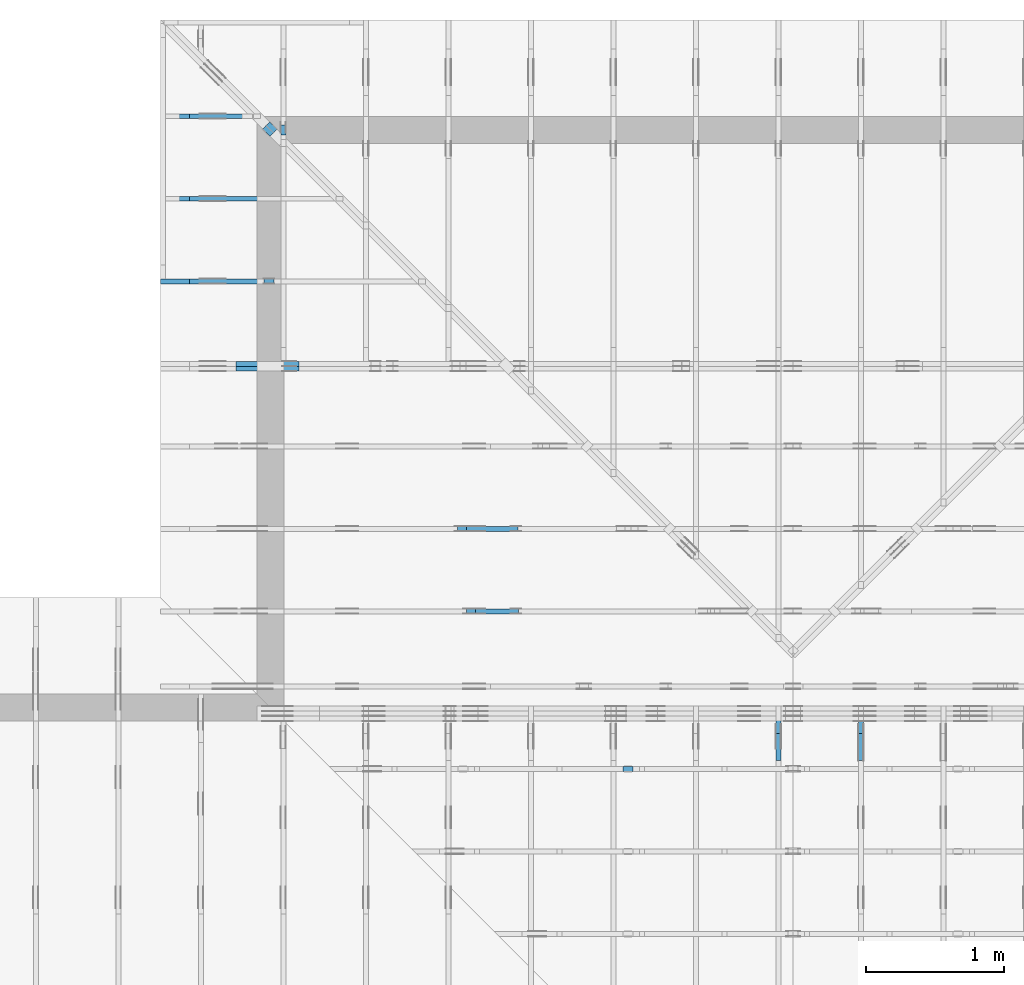
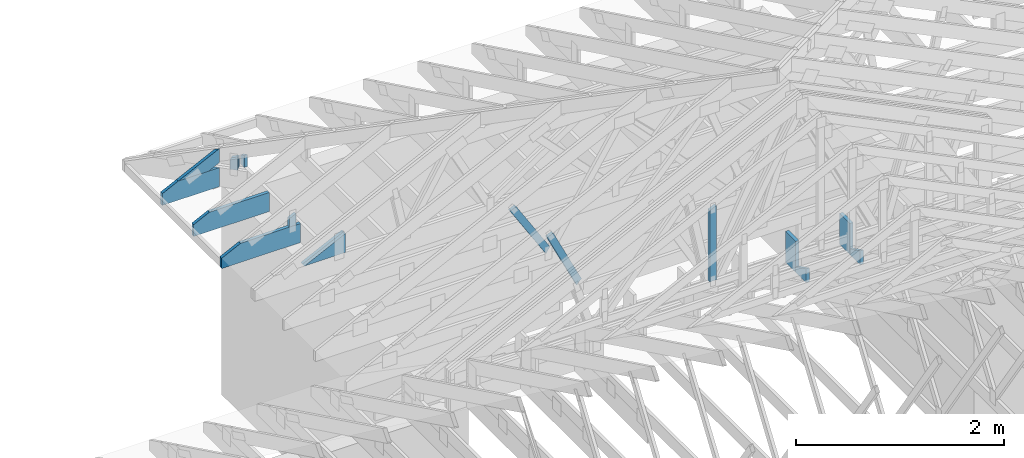
# One storey, part 46 of 159: 17 members, 11 elements without a shape of their own.
"""IFC2X3 building model written with IfcOpenShell, lengths in millimetres."""

import ifcopenshell
import ifcopenshell.guid

model = None  # the IFC model being written
_history = None  # IfcOwnerHistory: only IFC2X3 demands one
_inside = {}  # id of a spatial element -> (the spatial element, [elements in it])
_under = {}  # id of a project, library or spatial element -> (it, [spatial elements below it])
_declared = {}  # id of a project -> (the project, [libraries it declares])
_typed = {}  # id of a type object -> (the type object, [elements of that type])
_made_of = {}  # id of a material, layer set ... -> (it, [elements and type objects made of it])


def new_model(schema):
    """Start an empty IFC model of exactly this schema.

    Asked for "IFC4X3", IfcOpenShell would pick the latest addendum, in which some entities
    have other attributes; the version numbers below select the first issue.
    IFC2X3 requires an IfcOwnerHistory on every rooted entity: one is made here for all.
    """
    global model, _history
    if schema == "IFC4X3":
        model = ifcopenshell.file(schema_version=(4, 3, 0, 0))
    else:
        model = ifcopenshell.file(schema=schema)
    _inside.clear()
    _under.clear()
    _declared.clear()
    _typed.clear()
    _made_of.clear()
    _history = None
    if model.schema == "IFC2X3":
        org = make("IfcOrganization", Name="unknown")
        user = make(
            "IfcPersonAndOrganization",
            ThePerson=make("IfcPerson", FamilyName="unknown"),
            TheOrganization=org,
        )
        app = make(
            "IfcApplication",
            ApplicationDeveloper=org,
            Version="unknown",
            ApplicationFullName="unknown",
            ApplicationIdentifier="unknown",
        )
        _history = make(
            "IfcOwnerHistory",
            OwningUser=user,
            OwningApplication=app,
            ChangeAction="ADDED",
            CreationDate=0,
        )
    return model


def make(cls, **values):
    """One entity of the class cls with the attributes given. An attribute that is None is left unset."""
    return model.create_entity(
        cls, **{name: value for name, value in values.items() if value is not None}
    )


def rooted(cls, **values):
    """An entity with a GlobalId (a new one), such as an element, a storey or a relation."""
    return make(cls, GlobalId=ifcopenshell.guid.new(), OwnerHistory=_history, **values)


def si_unit(unit_type, name, prefix=None):
    """IfcSIUnit, for example si_unit("LENGTHUNIT", "METRE", prefix="MILLI")."""
    return make("IfcSIUnit", UnitType=unit_type, Prefix=prefix, Name=name)


def assignment(units):
    """IfcUnitAssignment: the units of a project."""
    return None if units is None else make("IfcUnitAssignment", Units=units)


def point(xyz):
    """IfcCartesianPoint."""
    return None if xyz is None else make("IfcCartesianPoint", Coordinates=xyz)


def direction(xyz):
    """IfcDirection."""
    return None if xyz is None else make("IfcDirection", DirectionRatios=xyz)


def frame(location, z_axis=None, x_axis=None):
    """IfcAxis2Placement3D, a coordinate frame: its origin and axes. An axis left out is left unset."""
    return make(
        "IfcAxis2Placement3D",
        Location=point(location),
        Axis=direction(z_axis),
        RefDirection=direction(x_axis),
    )


def frame_2d(location, x_axis=None):
    """IfcAxis2Placement2D, a coordinate frame in the plane: its origin and x axis."""
    return make(
        "IfcAxis2Placement2D", Location=point(location), RefDirection=direction(x_axis)
    )


def origin():
    """The frame at (0, 0, 0) with its axes left unset."""
    return frame((0.0, 0.0, 0.0))


def origin_with_axes():
    """The frame at (0, 0, 0) with the z axis (0, 0, 1) and the x axis (1, 0, 0) written out."""
    return frame((0.0, 0.0, 0.0), z_axis=(0.0, 0.0, 1.0), x_axis=(1.0, 0.0, 0.0))


def origin_2d():
    """The frame at (0, 0) in the plane with its x axis left unset."""
    return frame_2d((0.0, 0.0))


def place(relative_to, where):
    """IfcLocalPlacement: puts the frame where relative to a parent placement (None: the world)."""
    return make(
        "IfcLocalPlacement", PlacementRelTo=relative_to, RelativePlacement=where
    )


def context(
    kind, dimensions, precision=None, world=None, true_north=None, identifier=None
):
    """IfcGeometricRepresentationContext, for example the 3D "Model" context."""
    return make(
        "IfcGeometricRepresentationContext",
        ContextIdentifier=identifier,
        ContextType=kind,
        CoordinateSpaceDimension=dimensions,
        Precision=precision,
        WorldCoordinateSystem=world,
        TrueNorth=true_north,
    )


def project(units=None, contexts=None):
    """IfcProject with its units and contexts."""
    return rooted(
        "IfcProject",
        Name="project",
        RepresentationContexts=contexts,
        UnitsInContext=assignment(units),
    )


def spatial(cls, under=None, at=None, **own):
    """A site, building, storey or space (cls), placed at a placement, below another one or the project."""
    s = rooted(cls, ObjectPlacement=at, **own)
    if under is not None:
        _under.setdefault(under.id(), (under, []))[1].append(s)
    return s


def faces_of(points, faces, orient=None, outer=None):
    """IfcFace entities. A face is a list of loops; a loop is a list of indices into points, from 0.

    orient and outer hold one flag for each loop. By default every Orientation is true, the
    first loop of a face is its IfcFaceOuterBound and the others are IfcFaceBound.
    """
    made = []
    for i, loops in enumerate(faces):
        bounds = []
        for j, loop in enumerate(loops):
            is_outer = j == 0 if outer is None else outer[i][j]
            bounds.append(
                make(
                    "IfcFaceOuterBound" if is_outer else "IfcFaceBound",
                    Bound=make("IfcPolyLoop", Polygon=[points[k] for k in loop]),
                    Orientation=True if orient is None else orient[i][j],
                )
            )
        made.append(make("IfcFace", Bounds=bounds))
    return made


def faceted_brep(points, faces, orient=None, outer=None, voids=None):
    """IfcFacetedBrep: a solid bounded by flat faces; with voids (closed shells), ...WithVoids."""
    shared = [point(p) for p in points]
    hull = make("IfcClosedShell", CfsFaces=faces_of(shared, faces, orient, outer))
    if voids is None:
        return make("IfcFacetedBrep", Outer=hull)
    return make(
        "IfcFacetedBrepWithVoids",
        Outer=hull,
        Voids=[
            make(cls, CfsFaces=faces_of(shared, fs, o, b)) for cls, fs, o, b in voids
        ],
    )


def shape(context_of_items, identifier, shape_type, items):
    """IfcShapeRepresentation: the items that make up one representation, for example the "Body"."""
    return make(
        "IfcShapeRepresentation",
        ContextOfItems=context_of_items,
        RepresentationIdentifier=identifier,
        RepresentationType=shape_type,
        Items=items,
    )


def made_of(thing, what):
    """Note that an element or type object is made of a material, layer set ...; save() writes the relation."""
    if what is not None:
        _made_of.setdefault(what.id(), (what, []))[1].append(thing)
    return thing


def element(
    cls,
    number,
    at=None,
    inside=None,
    cuts=None,
    type_object=None,
    material=None,
    context=None,
    identifier="Body",
    shape_type=None,
    held_by="IfcProductDefinitionShape",
    body=None,
    shapes=None,
    **own,
):
    """One element of the class cls, such as IfcWall. Its Tag is "e" and its number.

    at: its placement. inside: the storey or other place that contains it. cuts: it is an
    opening in that element (IfcRelVoidsElement). A single representation is given by context,
    identifier, shape_type and body (its items); several are given by shapes. held_by: the class
    of the entity that holds the representations. save() writes the other relations.
    """
    e = rooted(cls, Tag="e%d" % number, ObjectPlacement=at, **own)
    if body is not None:
        shapes = [shape(context, identifier, shape_type, body)]
    if shapes is not None:
        e.Representation = make(held_by, Representations=shapes)
    if inside is not None:
        _inside.setdefault(inside.id(), (inside, []))[1].append(e)
    if cuts is not None:
        rooted(
            "IfcRelVoidsElement", RelatingBuildingElement=cuts, RelatedOpeningElement=e
        )
    if type_object is not None:
        _typed.setdefault(type_object.id(), (type_object, []))[1].append(e)
    return made_of(e, material)


def aggregate(whole, parts):
    """IfcRelAggregates: a whole, such as a stair, and the parts it consists of."""
    return rooted("IfcRelAggregates", RelatingObject=whole, RelatedObjects=parts)


def save(model, path):
    """Write the relations noted so far, then the file.

    IfcRelAggregates (storeys below a building ...), IfcRelContainedInSpatialStructure (elements
    in a storey), IfcRelDefinesByType, IfcRelAssociatesMaterial and IfcRelDeclares: one each for
    every whole, place, type object, material and project.
    """
    for whole, parts in _under.values():
        aggregate(whole, parts)
    for where, things in _inside.values():
        rooted(
            "IfcRelContainedInSpatialStructure",
            RelatedElements=things,
            RelatingStructure=where,
        )
    for kind, things in _typed.values():
        rooted("IfcRelDefinesByType", RelatedObjects=things, RelatingType=kind)
    for what, things in _made_of.values():
        rooted("IfcRelAssociatesMaterial", RelatedObjects=things, RelatingMaterial=what)
    for by, libraries in _declared.values():
        rooted("IfcRelDeclares", RelatingContext=by, RelatedDefinitions=libraries)
    model.write(path)


model = new_model("IFC2X3")

# Units and contexts
model_context = context("Model", 3, precision=1e-05, world=origin())
plan_context = context("Plan", 2, precision=1e-05, world=origin_2d())
ifc_project = project(units=[si_unit("LENGTHUNIT", "METRE", prefix="MILLI"), si_unit("AREAUNIT", "SQUARE_METRE"), si_unit("VOLUMEUNIT", "CUBIC_METRE"), si_unit("SOLIDANGLEUNIT", "STERADIAN"), si_unit("PLANEANGLEUNIT", "RADIAN"), si_unit("MASSUNIT", "GRAM"), si_unit("TIMEUNIT", "SECOND"), si_unit("THERMODYNAMICTEMPERATUREUNIT", "DEGREE_CELSIUS"), si_unit("LUMINOUSINTENSITYUNIT", "LUMEN")], contexts=[model_context, plan_context])

# Site, building, storey
site_placement = place(None, origin_with_axes())
site = spatial("IfcSite", under=ifc_project, at=site_placement, CompositionType="ELEMENT")
building_placement = place(site_placement, origin_with_axes())
building = spatial("IfcBuilding", under=site, at=building_placement, Name="Plan 1", CompositionType="ELEMENT")
storey_placement = place(building_placement, origin_with_axes())
storey = spatial("IfcBuildingStorey", under=building, at=storey_placement, Name="Etasje 1", CompositionType="ELEMENT", Elevation=0.0)

# Assembly, member
assembly_1_placement = place(storey_placement, frame((19200.01266310149, 9617.999978540158, 1.1021457184401395e-15), z_axis=(1.2246063538223773e-16, 1.0, 6.123031769111886e-17), x_axis=(-1.0, 1.2246063538223773e-16, 0.0)))
assembly_1 = element("IfcElementAssembly", 1, at=assembly_1_placement, inside=storey, Name="V12 (104)", AssemblyPlace="FACTORY", PredefinedType="TRUSS")
member_1_placement = place(assembly_1_placement, frame((6910.824282017095, 1071.8405838183317, -36.0), z_axis=(0.0, 0.0, 1.0), x_axis=(-0.43837114678907774, -0.8987940462991668, 0.0)))
member_1 = element("IfcMember", 2, at=member_1_placement, Name="V12-D64", context=model_context, shape_type="Brep", body=[
    faceted_brep([(744.1520057801918, 73.00022302085836, 36.0), (0.0, 73.00022302085836, 36.0), (0.00014432312946155434, 0.0, 36.0), (714.8608321408219, 0.0, 36.0), (0.0, 73.00022302085836, 0.0), (744.1520057801918, 73.00022302085836, 9.112932744880892e-14), (714.8608321408219, 0.0, 8.754231171384024e-14), (0.00014432312946155434, 0.0, 1.7673902134214898e-20), (6.50678757665446e-05, 0.0002128465330315521, 7.52316384526264e-37), (6.50678757687489e-05, 0.0002128465330315521, 36.0), (6.50678962337698e-05, 73.00021284653394, 36.0), (6.50678962315655e-05, 73.00021284653394, -8.511632342891698e-32), (714.8608697602031, 0.00021284653417008646, 4.1664479062748666e-29), (714.8608697602031, 0.00021284653417229075, 36.0), (6.50678757665446e-05, 0.00021284653303375634, 36.0), (6.50678757665446e-05, 0.00021284653303155204, 4.513898307157584e-36), (744.1520107425414, 73.00021284653388, 6.310887241768095e-30), (744.1520107425414, 73.00021284653388, 36.0), (714.8608697602032, 0.0002128465348789632, 36.0), (714.8608697602032, 0.0002128465348789632, 0.0), (6.506789623017539e-05, 73.00021284653394, 0.0), (6.506789623017539e-05, 73.00021284653394, 36.0), (744.1520107425413, 73.0002128465339, 36.0), (744.1520107425413, 73.0002128465339, -3.1554436208840472e-30)], [[[0, 1, 2, 3]], [[4, 5, 6, 7]], [[8, 9, 10, 11]], [[12, 13, 14, 15]], [[16, 17, 18, 19]], [[20, 21, 22, 23]]]),
])
aggregate(assembly_1, [member_1])

# Assembly, members
assembly_2_placement = place(storey_placement, frame((15075.02226140475, -699.9989301294845, 1.1021457184401395e-15), z_axis=(-1.0, 1.836909530733566e-16, 6.123031769111886e-17), x_axis=(-1.836909530733566e-16, -1.0, 0.0)))
assembly_2 = element("IfcElementAssembly", 3, at=assembly_2_placement, inside=storey, Name="T7 (103)", AssemblyPlace="FACTORY", PredefinedType="TRUSS")
member_2_placement = place(assembly_2_placement, frame((-9411.99893013318, 371.0, -36.0), z_axis=(0.0, 0.0, 1.0), x_axis=(-2.6074085653169515e-12, 1.0, 0.0)))
member_2 = element("IfcMember", 4, at=member_2_placement, Name="T7-S1", context=model_context, shape_type="Brep", body=[
    faceted_brep([(363.47723388723495, 198.0000933033716, 36.0), (5.162519300938584e-10, 198.0000933033716, 36.0), (0.0, 9.330431930720806e-05, 36.0), (363.4772338867187, 9.330431930720806e-05, 36.0), (5.162519300938584e-10, 198.0000933033716, 6.322053937660047e-26), (363.47723388723495, 198.0000933033716, 4.4511653008809024e-14), (363.4772338867187, 9.330431930720806e-05, 4.45116530087458e-14), (0.0, 9.330431930720806e-05, 0.0), (0.0, 0.0, 0.0), (2.204291436880279e-15, -5.7474038303501e-27, 36.0), (5.162615062011267e-10, 198.0, 36.0), (5.162593019096898e-10, 198.0, -4.513786253158592e-31), (363.47721516495375, 6.308078123434283e-08, -2.921223515766118e-30), (363.47721516495375, 6.308078343863427e-08, 36.0), (-3.825505976859566e-25, 2.204291436880279e-15, 36.0), (0.0, 0.0, 0.0), (363.47721516495375, 198.0000000612181, -3.16080787503955e-26), (363.47721516495375, 198.0000000612181, 36.0), (363.47721516495375, 6.308073352556676e-08, 36.0), (363.47721516495375, 6.308073352556676e-08, 0.0), (5.162519300938584e-10, 198.0, 0.0), (5.162519300938584e-10, 198.0, 36.0), (363.47721516547, 198.0000000612181, 36.0), (363.47721516547, 198.0000000612181, -1.5777218104420236e-30)], [[[0, 1, 2, 3]], [[4, 5, 6, 7]], [[8, 9, 10, 11]], [[12, 13, 14, 15]], [[16, 17, 18, 19]], [[20, 21, 22, 23]]]),
])
member_3_placement = place(assembly_2_placement, frame((-9213.998930133188, 371.0, -36.0), z_axis=(0.0, 0.0, 1.0), x_axis=(-1.7615569541788202e-10, 1.0, 0.0)))
member_3 = element("IfcMember", 5, at=member_3_placement, Name="T7-S5", context=model_context, shape_type="Brep", body=[
    faceted_brep([(66.21466067941009, 198.00009329264867, 36.0), (3.4878837595897494e-08, 198.00009329264867, 36.0), (0.0, 9.330431203125045e-05, 36.0), (162.7857055664063, 9.330431203125045e-05, 36.0), (3.4878837595897494e-08, 198.00009329264867, 4.271284613387488e-24), (66.21466067941009, 198.00009329264867, 8.108689418419832e-15), (162.7857055664063, 9.330431203125045e-05, 1.9934840934807988e-14), (0.0, 9.330431203125045e-05, 0.0), (-2.605355528885784e-24, 6.255140760913491e-08, 1.5952674669991638e-40), (2.2042914342749235e-15, 6.255140760913491e-08, 36.0), (3.487882230300644e-08, 198.00000006253686, 36.0), (3.4878820098715006e-08, 198.00000006253686, 1.071358042460672e-30), (162.78571493316844, -3.9667248731015275e-14, 2.4288382424236155e-30), (162.78571493316844, -3.7462957294134996e-14, 36.0), (8.470130163630552e-25, 6.255140981342635e-08, 36.0), (0.0, 6.255140760913491e-08, 0.0), (66.21466011511593, 198.0, 0.0), (66.21466011511593, 198.0, 36.0), (162.78571493316844, 1.4210854715202004e-14, 36.0), (162.78571493316846, 1.4210854715202004e-14, 1.5777218104420236e-30), (3.4878837595897494e-08, 198.00000006253686, 0.0), (3.4878837595897494e-08, 198.00000006253686, 36.0), (66.21466011511592, 198.0, 36.0), (66.21466011511592, 198.0, 0.0)], [[[0, 1, 2, 3]], [[4, 5, 6, 7]], [[8, 9, 10, 11]], [[12, 13, 14, 15]], [[16, 17, 18, 19]], [[20, 21, 22, 23]]]),
])
aggregate(assembly_2, [member_2, member_3])

assembly_3_placement = place(storey_placement, frame((14475.022261404752, -699.9989301294836, 1.1021457184401395e-15), z_axis=(-1.0, 1.836909530733566e-16, 6.123031769111886e-17), x_axis=(-1.836909530733566e-16, -1.0, 0.0)))
assembly_3 = element("IfcElementAssembly", 6, at=assembly_3_placement, inside=storey, Name="T10 (102)", AssemblyPlace="FACTORY", PredefinedType="TRUSS")
member_4_placement = place(assembly_3_placement, frame((-9411.99893013318, 371.0, -36.0), z_axis=(0.0, 0.0, 1.0), x_axis=(-2.6074085653169515e-12, 1.0, 0.0)))
member_4 = element("IfcMember", 7, at=member_4_placement, Name="T10-S1", context=model_context, shape_type="Brep", body=[
    faceted_brep([(363.47723388723495, 198.0000933033716, 36.0), (5.162519300938584e-10, 198.0000933033716, 36.0), (0.0, 9.330431930720806e-05, 36.0), (363.4772338867187, 9.330431930720806e-05, 36.0), (5.162519300938584e-10, 198.0000933033716, 6.322053937660047e-26), (363.47723388723495, 198.0000933033716, 4.4511653008809024e-14), (363.4772338867187, 9.330431930720806e-05, 4.45116530087458e-14), (0.0, 9.330431930720806e-05, 0.0), (0.0, 0.0, 0.0), (2.204291436880279e-15, -5.7474038303501e-27, 36.0), (5.162615062011267e-10, 198.0, 36.0), (5.162593019096898e-10, 198.0, -4.513786253158592e-31), (363.47721516495375, 6.308078123434283e-08, -2.921223515766118e-30), (363.47721516495375, 6.308078343863427e-08, 36.0), (-3.825505976859566e-25, 2.204291436880279e-15, 36.0), (0.0, 0.0, 0.0), (363.47721516495375, 198.0000000612181, -3.16080787503955e-26), (363.47721516495375, 198.0000000612181, 36.0), (363.47721516495375, 6.308073352556676e-08, 36.0), (363.47721516495375, 6.308073352556676e-08, 0.0), (5.162519300938584e-10, 198.0, 0.0), (5.162519300938584e-10, 198.0, 36.0), (363.47721516547, 198.0000000612181, 36.0), (363.47721516547, 198.0000000612181, -1.5777218104420236e-30)], [[[0, 1, 2, 3]], [[4, 5, 6, 7]], [[8, 9, 10, 11]], [[12, 13, 14, 15]], [[16, 17, 18, 19]], [[20, 21, 22, 23]]]),
])
member_5_placement = place(assembly_3_placement, frame((-9213.998930133188, 371.0, -36.0), z_axis=(0.0, 0.0, 1.0), x_axis=(-1.7615569541788202e-10, 1.0, 0.0)))
member_5 = element("IfcMember", 8, at=member_5_placement, Name="T10-S5", context=model_context, shape_type="Brep", body=[
    faceted_brep([(66.21466067941009, 198.00009329264867, 36.0), (3.4878837595897494e-08, 198.00009329264867, 36.0), (0.0, 9.330431203125045e-05, 36.0), (162.7857055664063, 9.330431203125045e-05, 36.0), (3.4878837595897494e-08, 198.00009329264867, 4.271284613387488e-24), (66.21466067941009, 198.00009329264867, 8.108689418419832e-15), (162.7857055664063, 9.330431203125045e-05, 1.9934840934807988e-14), (0.0, 9.330431203125045e-05, 0.0), (-2.605355528885784e-24, 6.255140760913491e-08, 1.5952674669991638e-40), (2.2042914342749235e-15, 6.255140760913491e-08, 36.0), (3.487882230300644e-08, 198.00000006253686, 36.0), (3.4878820098715006e-08, 198.00000006253686, 1.071358042460672e-30), (162.78571493316844, -3.9667248731015275e-14, 2.4288382424236155e-30), (162.78571493316844, -3.7462957294134996e-14, 36.0), (8.470130163630552e-25, 6.255140981342635e-08, 36.0), (0.0, 6.255140760913491e-08, 0.0), (66.21466011511593, 198.0, 0.0), (66.21466011511593, 198.0, 36.0), (162.78571493316844, 1.4210854715202004e-14, 36.0), (162.78571493316846, 1.4210854715202004e-14, 1.5777218104420236e-30), (3.4878837595897494e-08, 198.00000006253686, 0.0), (3.4878837595897494e-08, 198.00000006253686, 36.0), (66.21466011511592, 198.0, 36.0), (66.21466011511592, 198.0, 0.0)], [[[0, 1, 2, 3]], [[4, 5, 6, 7]], [[8, 9, 10, 11]], [[12, 13, 14, 15]], [[16, 17, 18, 19]], [[20, 21, 22, 23]]]),
])
aggregate(assembly_3, [member_4, member_5])

assembly_4_placement = place(storey_placement, frame((19200.01266310149, 11417.999978540158, 0.0), z_axis=(1.2246063538223773e-16, 1.0, 6.123031769111886e-17), x_axis=(-1.0, 1.2246063538223773e-16, 0.0)))
assembly_4 = element("IfcElementAssembly", 9, at=assembly_4_placement, inside=storey, Name="V9 (1)", AssemblyPlace="FACTORY", PredefinedType="TRUSS")
member_6_placement = place(assembly_4_placement, frame((8193.9873046875, 223.0, -36.0), z_axis=(0.0, 0.0, 1.0), x_axis=(1.0, 0.0, 0.0)))
member_6 = element("IfcMember", 10, at=member_6_placement, Name="V9-KI3", context=model_context, shape_type="Brep", body=[
    faceted_brep([(0.0, 223.0, 36.0), (0.0, 0.0, 36.0), (457.2177734375, 0.0, 36.0), (0.0, 223.0, 0.0), (457.2177734375, 0.0, 0.0), (0.0, 0.0, 0.0), (0.00018211813039670233, 0.0, 0.0), (0.00018211813039890662, -2.6993892992798474e-31, 36.0), (0.00018211813042621534, 223.0, 36.0), (0.00018211813042401105, 223.0, -1.67212096573961e-30), (457.21793879009783, -8.398679893858869e-14, 5.1425383808699095e-30), (457.21793879009783, -8.178250750170841e-14, 36.0), (0.00018211813039670233, 2.2042579834273344e-15, 36.0), (0.00018211813039670233, -3.3453452944508083e-20, 2.0483655516571257e-36), (0.00018211813039670233, 223.00000000000003, 1.2764860230108856e-30), (0.00018211813039670233, 223.00000000000003, 36.0), (457.21793879009783, -2.842170943040401e-14, 36.0), (457.21793879009783, -2.842170943040401e-14, -3.114004965666352e-31)], [[[0, 1, 2]], [[3, 4, 5]], [[6, 7, 8, 9]], [[10, 11, 12, 13]], [[14, 15, 16, 17]]]),
])
member_7_placement = place(assembly_4_placement, frame((8193.9873046875, 223.0, -72.0), z_axis=(0.0, 0.0, 1.0), x_axis=(1.0, 0.0, 0.0)))
member_7 = element("IfcMember", 11, at=member_7_placement, Name="V9-KI3", context=model_context, shape_type="Brep", body=[
    faceted_brep([(0.0, 223.0, 36.0), (0.0, 0.0, 36.0), (457.2177734375, 0.0, 36.0), (0.0, 223.0, 0.0), (457.2177734375, 0.0, 0.0), (0.0, 0.0, 0.0), (0.00018211813039670233, 0.0, 0.0), (0.00018211813039890662, -2.6993892992798474e-31, 36.0), (0.00018211813042621534, 223.0, 36.0), (0.00018211813042401105, 223.0, -1.67212096573961e-30), (457.21793879009783, -8.398679893858869e-14, 5.1425383808699095e-30), (457.21793879009783, -8.178250750170841e-14, 36.0), (0.00018211813039670233, 2.2042579834273344e-15, 36.0), (0.00018211813039670233, -3.3453452944508083e-20, 2.0483655516571257e-36), (0.00018211813039670233, 223.00000000000003, 1.2764860230108856e-30), (0.00018211813039670233, 223.00000000000003, 36.0), (457.21793879009783, -2.842170943040401e-14, 36.0), (457.21793879009783, -2.842170943040401e-14, -3.114004965666352e-31)], [[[0, 1, 2]], [[3, 4, 5]], [[6, 7, 8, 9]], [[10, 11, 12, 13]], [[14, 15, 16, 17]]]),
])
aggregate(assembly_4, [member_6, member_7])

# Assembly, member
assembly_5_placement = place(storey_placement, frame((19200.01266310149, 10217.999978540158, 1.1021457184401395e-15), z_axis=(1.2246063538223773e-16, 1.0, 6.123031769111886e-17), x_axis=(-1.0, 1.2246063538223773e-16, 0.0)))
assembly_5 = element("IfcElementAssembly", 12, at=assembly_5_placement, inside=storey, Name="V11 (60)", AssemblyPlace="FACTORY", PredefinedType="TRUSS")
member_8_placement = place(assembly_5_placement, frame((6978.707542797693, 1047.0527373098932, -36.0), z_axis=(0.0, 0.0, 1.0), x_axis=(-0.528147112913961, -0.849152887954017, 0.0)))
member_8 = element("IfcMember", 13, at=member_8_placement, Name="V11-D63", context=model_context, shape_type="Brep", body=[
    faceted_brep([(750.745866036712, 72.99995797110569, 36.0), (1.089474062609952e-05, 72.99995797110569, 36.0), (7.518461372288584, 0.0001498857118349406, 36.0), (715.457328546925, 0.0001498857118349406, 36.0), (1.089474062609952e-05, 72.99995797110569, 1.3341768593968256e-21), (750.745866036712, 72.99995797110569, 9.193681576544408e-14), (715.457328546925, 0.0001498857118349406, 8.761535904273485e-14), (7.518461372288584, 0.0001498857118349406, 9.20715556747271e-16), (7.518511230056902, 9.897125346469693e-05, 9.920094071949097e-32), (7.518511230056904, 9.897125346491897e-05, 36.0), (7.993605777301127e-15, 73.00009897125348, 36.0), (6.217248937900877e-15, 73.00009897125348, -3.5176415065138226e-31), (715.4572499096312, 9.897125648156507e-05, -1.7657845813080454e-29), (715.4572499096312, 9.897125648376936e-05, 36.0), (7.518511230056902, 9.897125346993176e-05, 36.0), (7.518511230056902, 9.897125346772746e-05, -1.8556034087617207e-31), (750.7457783389327, 73.0000989712562, 1.2093723226358405e-30), (750.7457783389327, 73.0000989712562, 36.0), (715.4572499096312, 9.897125619318103e-05, 36.0), (715.4572499096312, 9.897125619318103e-05, -5.3513679226888236e-30), (0.0, 73.00009897125346, 0.0), (0.0, 73.00009897125346, 36.0), (750.7457783389327, 73.00009897125625, 36.0), (750.7457783389327, 73.00009897125625, 3.1554436208840472e-30)], [[[0, 1, 2, 3]], [[4, 5, 6, 7]], [[8, 9, 10, 11]], [[12, 13, 14, 15]], [[16, 17, 18, 19]], [[20, 21, 22, 23]]]),
])
aggregate(assembly_5, [member_8])

# Assembly, members
assembly_6_placement = place(storey_placement, frame((9974.55681897877, 13874.544134417441, 2.204291436880279e-15), z_axis=(-0.7071067811865477, -0.7071067811865474, 6.123031769111886e-17), x_axis=(0.7071067811865474, -0.7071067811865477, 0.0)))
assembly_6 = element("IfcElementAssembly", 14, at=assembly_6_placement, inside=storey, Name="GR2 (61)", AssemblyPlace="FACTORY", PredefinedType="TRUSS")
member_9_placement = place(assembly_6_placement, frame((1086.199951171875, 357.021484375, -36.0), z_axis=(0.0, 0.0, 1.0), x_axis=(-1.836909530733566e-16, -1.0, 0.0)))
member_9 = element("IfcMember", 15, at=member_9_placement, Name="GR2-D74", context=model_context, shape_type="Brep", body=[
    faceted_brep([(134.02148437500003, 73.0, 36.0), (0.0, 73.0, 36.0), (25.176177978515625, 0.0, 36.0), (134.02148437500003, 0.0, 36.0), (0.0, 73.0, 0.0), (134.02148437500003, 73.0, 1.641235613143315e-14), (134.02148437500003, 0.0, 1.641235613143315e-14), (25.176177978515625, 0.0, 3.083090751745325e-15), (25.176174520570953, 1.6222267731791362e-05, 2.5293706552205644e-32), (25.176174520570957, 1.622226773267954e-05, 36.0), (6.003574771540343e-06, 73.00001622226775, 36.0), (6.0035747679876295e-06, 73.00001622226775, -1.0015179205859255e-30), (134.02148437491607, 1.6222267707172827e-05, 1.5074007291102963e-30), (134.02148437491607, 1.622226770937712e-05, 36.0), (25.176174520570953, 1.622226772937102e-05, 36.0), (25.176174520570953, 1.6222267727166728e-05, 2.83167937474667e-31), (134.02148437491607, 73.00001622226773, -2.216699143671043e-27), (134.02148437491607, 73.00001622226773, 36.0), (134.02148437491607, 1.6222267731791362e-05, 36.0), (134.02148437491607, 1.6222267731791362e-05, 0.0), (6.003574753776775e-06, 73.00001622226773, 0.0), (6.003574753776775e-06, 73.00001622226773, 36.0), (134.02148437495228, 73.00001622226772, 36.0), (134.02148437495228, 73.00001622226772, -7.888609052210118e-31)], [[[0, 1, 2, 3]], [[4, 5, 6, 7]], [[8, 9, 10, 11]], [[12, 13, 14, 15]], [[16, 17, 18, 19]], [[20, 21, 22, 23]]]),
])
member_10_placement = place(assembly_6_placement, frame((1086.199951171875, 357.021484375, -72.0), z_axis=(0.0, 0.0, 1.0), x_axis=(-1.836909530733566e-16, -1.0, 0.0)))
member_10 = element("IfcMember", 16, at=member_10_placement, Name="GR2-D74", context=model_context, shape_type="Brep", body=[
    faceted_brep([(134.02148437500003, 73.0, 36.0), (0.0, 73.0, 36.0), (25.176177978515625, 0.0, 36.0), (134.02148437500003, 0.0, 36.0), (0.0, 73.0, 0.0), (134.02148437500003, 73.0, 1.641235613143315e-14), (134.02148437500003, 0.0, 1.641235613143315e-14), (25.176177978515625, 0.0, 3.083090751745325e-15), (25.176174520570953, 1.6222267731791362e-05, 2.5293706552205644e-32), (25.176174520570957, 1.622226773267954e-05, 36.0), (6.003574771540343e-06, 73.00001622226775, 36.0), (6.0035747679876295e-06, 73.00001622226775, -1.0015179205859255e-30), (134.02148437491607, 1.6222267707172827e-05, 1.5074007291102963e-30), (134.02148437491607, 1.622226770937712e-05, 36.0), (25.176174520570953, 1.622226772937102e-05, 36.0), (25.176174520570953, 1.6222267727166728e-05, 2.83167937474667e-31), (134.02148437491607, 73.00001622226773, -2.216699143671043e-27), (134.02148437491607, 73.00001622226773, 36.0), (134.02148437491607, 1.6222267731791362e-05, 36.0), (134.02148437491607, 1.6222267731791362e-05, 0.0), (6.003574753776775e-06, 73.00001622226773, 0.0), (6.003574753776775e-06, 73.00001622226773, 36.0), (134.02148437495228, 73.00001622226772, 36.0), (134.02148437495228, 73.00001622226772, -7.888609052210118e-31)], [[[0, 1, 2, 3]], [[4, 5, 6, 7]], [[8, 9, 10, 11]], [[12, 13, 14, 15]], [[16, 17, 18, 19]], [[20, 21, 22, 23]]]),
])
aggregate(assembly_6, [member_9, member_10])

# Assembly, member
assembly_7_placement = place(storey_placement, frame((10875.022261404756, 13899.999978540158, 1.1021457184401395e-15), z_axis=(-1.0, 1.836909530733566e-16, 6.123031769111886e-17), x_axis=(-1.836909530733566e-16, -1.0, 0.0)))
assembly_7 = element("IfcElementAssembly", 17, at=assembly_7_placement, inside=storey, Name="S30 (72)", AssemblyPlace="FACTORY", PredefinedType="TRUSS")
member_11_placement = place(assembly_7_placement, frame((762.5, 362.835490556613, -36.0), z_axis=(0.0, 0.0, 1.0), x_axis=(-1.836909530733566e-16, -1.0, 0.0)))
member_11 = element("IfcMember", 18, at=member_11_placement, Name="S30-D72", context=model_context, shape_type="Brep", body=[
    faceted_brep([(139.835490556613, 73.00000000000011, 36.0), (1.0820284842338879e-05, 73.00000000000011, 36.0), (35.604472490206774, 0.0, 36.0), (139.835490556613, 0.0, 36.0), (1.0820284842338879e-05, 73.00000000000011, 1.325058956809615e-21), (139.835490556613, 73.00000000000011, 1.7124343022549732e-14), (139.835490556613, 0.0, 1.7124343022549732e-14), (35.604472490206774, 0.0, 4.360146323600126e-15), (35.60447896550848, 1.7763568394002505e-15, -3.94430452610506e-31), (35.60447896550848, 3.552713678800501e-15, 36.0), (1.0658141036401503e-14, 73.00000000000001, 36.0), (7.105427357601002e-15, 73.00000000000001, -3.94430452610506e-31), (139.8354905559078, 5.967783702856783e-14, 3.306988270615201e-30), (139.8354905559078, 6.188212846544811e-14, 36.0), (35.60447896550846, -1.1547312833817681e-14, 36.0), (35.60447896550846, -1.375160427069796e-14, 8.42015098257383e-31), (139.8354905559078, 73.00000000000011, -1.8333127437336314e-27), (139.8354905559078, 73.00000000000011, 36.0), (139.8354905559078, 1.1368683772161603e-13, 36.0), (139.8354905559078, 1.1368683772161603e-13, 0.0), (0.0, 73.0, 0.0), (0.0, 73.0, 36.0), (139.83549055593772, 73.00000000000014, 36.0), (139.83549055593772, 73.00000000000014, 1.5777218104420236e-30)], [[[0, 1, 2, 3]], [[4, 5, 6, 7]], [[8, 9, 10, 11]], [[12, 13, 14, 15]], [[16, 17, 18, 19]], [[20, 21, 22, 23]]]),
])
aggregate(assembly_7, [member_11])

# Assembly, members
assembly_8_placement = place(storey_placement, frame((10000.012663101486, 11981.999978540158, 1.1021457184401395e-15), z_axis=(0.0, -1.0, 6.123031769111886e-17), x_axis=(1.0, 0.0, 0.0)))
assembly_8 = element("IfcElementAssembly", 19, at=assembly_8_placement, inside=storey, Name="S26 (76)", AssemblyPlace="FACTORY", PredefinedType="TRUSS")
member_12_placement = place(assembly_8_placement, frame((875.00959830327, 223.00000000093067, -36.0), z_axis=(0.0, 0.0, 1.0), x_axis=(-1.0, 1.010639055082363e-15, 0.0)))
member_12 = element("IfcMember", 20, at=member_12_placement, Name="S26-U24", context=model_context, shape_type="Brep", body=[
    faceted_brep([(875.0095983032697, 223.00000000093155, 36.0), (1.5783738490426913e-05, 223.00000000093155, 36.0), (1.578373871780059e-05, 9.306688752985792e-10, 36.0), (663.8283086304184, 9.306688752985792e-10, 36.0), (875.0095660922563, 102.99998474214249, 36.0), (1.5783738490426913e-05, 223.00000000093155, 1.9328866442447615e-21), (875.0095983032697, 223.00000000093155, 1.0715423137377501e-13), (875.0095660922563, 102.99998474214249, 1.0715422742919384e-13), (663.8283086304184, 9.306688752985792e-10, 8.129283645959724e-14), (1.578373871780059e-05, 9.306688752985792e-10, 1.9328866720890862e-21), (2.2737367544346834e-13, 9.306688752985792e-10, -1.4467005345689411e-41), (2.295779668803486e-13, 9.306688752985792e-10, 36.0), (5.88229009774597e-14, 223.00000000093067, 36.0), (5.6618609540579425e-14, 223.00000000093067, -3.46677544939909e-30), (663.8283026196625, 1.6133500928177198e-13, -9.878593873028574e-30), (663.8283026196625, 1.6353930071865226e-13, 36.0), (2.2737367544323514e-13, 9.306710795900161e-10, 36.0), (2.2737367544323206e-13, 9.306688752985792e-10, 0.0), (875.0095660922564, 102.9999842907564, 1.5777218104420236e-29), (875.0095660922564, 102.9999842907564, 36.0), (663.8283026196626, -1.7053025658242404e-13, 36.0), (663.8283026196626, -1.7053025658242404e-13, 9.466330862652142e-30), (875.0095384444145, 223.00000000093155, -3.665176722326719e-21), (875.0095384444145, 223.00000000093155, 36.0), (875.0095384444145, 102.99998429075663, 36.0), (875.0095384444145, 102.99998429075663, -1.6928861372476246e-21), (0.0, 223.00000000093067, 0.0), (0.0, 223.00000000093067, 36.0), (875.0095983032697, 223.00000000093158, 36.0), (875.0095983032697, 223.00000000093158, 3.1554436208840472e-30)], [[[0, 1, 2, 3, 4]], [[5, 6, 7, 8, 9]], [[10, 11, 12, 13]], [[14, 15, 16, 17]], [[18, 19, 20, 21]], [[22, 23, 24, 25]], [[26, 27, 28, 29]]]),
])
member_13_placement = place(assembly_8_placement, frame((751.0047991516349, 357.2289123535157, -36.0), z_axis=(0.0, 0.0, 1.0), x_axis=(-1.836909530733566e-16, -1.0, 0.0)))
member_13 = element("IfcMember", 21, at=member_13_placement, Name="S26-D73", context=model_context, shape_type="Brep", body=[
    faceted_brep([(134.22891235351565, 73.000022625709, 36.0), (0.0, 73.000022625709, 36.0), (35.60449218750006, 2.2625708879786544e-05, 36.0), (134.22891235351565, 2.2625708879786544e-05, 36.0), (0.0, 73.000022625709, 0.0), (134.22891235351565, 73.000022625709, 1.6437757893478225e-14), (134.22891235351565, 2.2625708879786544e-05, 1.6437757893478225e-14), (35.60449218750006, 2.2625708879786544e-05, 4.360148735743176e-15), (35.604484827829886, 0.0, -3.944304526105059e-31), (35.604484827829886, 1.7763568394002505e-15, 36.0), (5.862479621754346e-06, 73.0, 36.0), (5.8624796182016325e-06, 73.0, -3.944304526105059e-31), (134.22891235334168, 5.3520408623451873e-14, 3.684009568020769e-30), (134.22891235334168, 5.572470006033215e-14, 36.0), (35.60448482782988, -1.3754973034631002e-14, 36.0), (35.60448482782988, -1.595926447151128e-14, 9.77190833707222e-31), (134.22891235334168, 73.00000000000011, -6.271444196507044e-27), (134.22891235334168, 73.00000000000011, 36.0), (134.22891235334168, 1.1368683772161603e-13, 36.0), (134.22891235334168, 1.1368683772161603e-13, 0.0), (5.862479611096205e-06, 73.0, 0.0), (5.862479611096205e-06, 73.0, 36.0), (134.2289123534441, 73.00000000000014, 36.0), (134.2289123534441, 73.00000000000014, 1.5777218104420236e-30)], [[[0, 1, 2, 3]], [[4, 5, 6, 7]], [[8, 9, 10, 11]], [[12, 13, 14, 15]], [[16, 17, 18, 19]], [[20, 21, 22, 23]]]),
])
aggregate(assembly_8, [member_12, member_13])

# Assembly, member
assembly_9_placement = place(storey_placement, frame((10036.01266309785, 12581.999978540158, 1.1021457184401395e-15), z_axis=(0.0, -1.0, 6.123031769111886e-17), x_axis=(1.0, 0.0, 0.0)))
assembly_9 = element("IfcElementAssembly", 22, at=assembly_9_placement, inside=storey, Name="S27 (77)", AssemblyPlace="FACTORY", PredefinedType="TRUSS")
member_14_placement = place(assembly_9_placement, frame((839.0095983069061, 223.0, -36.0), z_axis=(0.0, 0.0, 1.0), x_axis=(-1.0, 1.010639055082363e-15, 0.0)))
member_14 = element("IfcMember", 23, at=member_14_placement, Name="S27-U26", context=model_context, shape_type="Brep", body=[
    faceted_brep([(839.0095983069059, 222.9999999999863, 36.0), (1.57873746502446e-05, 222.9999999999863, 36.0), (1.5787374877618277e-05, 0.0, 36.0), (663.8283086340546, 0.0, 36.0), (839.009598306957, 85.44161987304773, 36.0), (1.57873746502446e-05, 222.9999999999863, 1.933331930686387e-21), (839.0095983069059, 222.9999999999863, 1.0274564850045974e-13), (839.009598306957, 85.44161987304773, 1.02745648500466e-13), (663.8283086340546, 0.0, 8.129283646004253e-14), (1.5787374877618277e-05, 0.0, 1.9333319585307117e-21), (2.2737367544323206e-13, 0.0, 0.0), (2.2957796688011234e-13, 1.68786515503886e-30, 36.0), (5.882290097722342e-14, 223.0, 36.0), (5.6618609540343146e-14, 223.0, -3.466775449384624e-30), (663.828302621436, 4.676587191889232e-13, 1.313159519899984e-29), (663.828302621436, 4.698630106258035e-13, 36.0), (2.2737367544323206e-13, 2.2042914368802057e-15, 36.0), (2.2737367544323206e-13, -7.345737267614091e-29, 4.4978182657150214e-45), (839.009598306957, 85.44162681317619, 5.594601464871939e-30), (839.009598306957, 85.44162681317619, 36.0), (663.8283026214361, 6.821210263296962e-13, 36.0), (663.8283026214361, 6.821210263296962e-13, 4.993997748019785e-30), (839.0095983069887, 222.9999999999863, 5.06764245513978e-27), (839.0095983069887, 222.9999999999863, 36.0), (839.0095983069887, 85.44162681317624, 36.0), (839.0095983069887, 85.44162681317624, 1.937442383222805e-27), (0.0, 223.0, 0.0), (0.0, 223.0, 36.0), (839.0095983069059, 222.99999999998653, 36.0), (839.0095983069059, 222.99999999998653, 1.4199496293978212e-29)], [[[0, 1, 2, 3, 4]], [[5, 6, 7, 8, 9]], [[10, 11, 12, 13]], [[14, 15, 16, 17]], [[18, 19, 20, 21]], [[22, 23, 24, 25]], [[26, 27, 28, 29]]]),
])
aggregate(assembly_9, [member_14])

# Assembly, members
assembly_10_placement = place(storey_placement, frame((10036.012663099562, 13181.999978540158, 1.1021457184401395e-15), z_axis=(0.0, -1.0, 6.123031769111886e-17), x_axis=(1.0, 0.0, 0.0)))
assembly_10 = element("IfcElementAssembly", 24, at=assembly_10_placement, inside=storey, Name="S28 (1)", AssemblyPlace="FACTORY", PredefinedType="TRUSS")
member_15_placement = place(assembly_10_placement, frame((240.06021636109466, 89.97847603909072, -36.00000124009921), z_axis=(0.0, 0.0, 1.0), x_axis=(0.8987940462991669, 0.43837114678907757, 0.0)))
member_15 = element("IfcMember", 25, at=member_15_placement, Name="S28-O76", context=model_context, shape_type="Brep", body=[
    faceted_brep([(507.243017701081, 147.9999954429179, 35.9999824541743), (435.05859374999994, 6.262113743105147e-07, 35.99997942397806), (395.0049473690259, 5.684341886080802e-14, 7.986955381511507e-07), (467.18937132010694, 148.0000035510673, 8.526512829121202e-14), (5.3819697427570645e-06, 148.00000062381577, 2.3121615626564562e-06), (5.3819697427570645e-06, 148.00000062381582, 36.000001240098314), (507.24301685657906, 148.0000006238159, 35.99997942397796), (467.1893707689327, 148.00000062381585, 2.3121615626564562e-06), (9.699900260784489e-06, 148.0000006247181, 1.2400992090988451e-06), (467.189371272166, 148.0000006247181, 1.240099266311151e-06), (395.00494591816187, 6.238870469132962e-07, 1.2400992574714005e-06), (303.4449865065409, 6.238870469132962e-07, 1.2400992462589096e-06), (303.44497892517245, 6.253860078686557e-07, 1.2400992090988439e-06), (303.44497892517245, 6.253860078686557e-07, 36.00000124009921), (7.212041303716887e-06, 148.00000216632623, 36.00000124009921), (7.212041303716887e-06, 148.0000021663262, 1.2400992090988439e-06), (435.05859425307597, 6.259602467082088e-07, 35.999978351915615), (303.44498112441386, 6.259601539880693e-07, 36.00000124009921), (303.44498112441386, 6.259601517837779e-07, 1.2400992090988439e-06), (395.0049481654296, 6.259602162866271e-07, 1.2400992090988439e-06), (507.2430191040039, 148.00000062621135, 36.00000124009921), (0.0, 148.00000062621135, 36.00000124009921), (303.4449768066405, 6.253860362903652e-07, 36.00000124009921), (435.0585937499999, 6.253860362903652e-07, 36.00000124009921)], [[[0, 1, 2, 3]], [[4, 5, 6, 7]], [[8, 9, 10, 11]], [[12, 13, 14, 15]], [[16, 17, 18, 19]], [[20, 21, 22, 23]]]),
])
member_16_placement = place(assembly_10_placement, frame((631.0883178710429, 223.00000069013822, -36.00000168119519), z_axis=(0.0, 0.0, 1.0), x_axis=(-1.0, 1.4547282649324256e-15, 0.0)))
member_16 = element("IfcMember", 26, at=member_16_placement, Name="S28-U29", context=model_context, shape_type="Brep", body=[
    faceted_brep([(36.00000742124679, 6.90138281666054e-07, 3.745004981681177e-07), (2.7930673134335393e-05, 6.901382221258245e-07, 35.99997986507415), (2.7930673009990414e-05, 223.00000069013822, 35.99997986507391), (36.000007421246764, 223.00000069013828, 3.7450015355489086e-07), (455.9070103525481, 6.901381383798314e-07, 2.7532577533406766e-06), (455.9070103525481, 6.901381405841229e-07, 36.00000168119451), (2.7930673127229966e-05, 6.901382243301096e-07, 35.99997986507416), (36.00000504248953, 6.901382155129495e-07, 2.7532577533406766e-06), (36.00000611455175, 223.00000069013828, 1.6811951910288272e-06), (631.0883239856458, 223.00000069013828, 1.6811952639037206e-06), (631.0883239856458, 85.44162819257969, 1.6811952639037206e-06), (455.9070190540052, 6.901388758251414e-07, 1.6811952424509068e-06), (36.00000611455209, 6.901388758251414e-07, 1.6811951910288272e-06), (2.900273534578446e-05, 223.00000069013828, 35.99997879301159), (631.0883239856455, 223.00000069013825, 36.00000168119519), (631.0883239856455, 223.00000069013825, 1.6811951866202435e-06), (36.00000611455175, 223.00000069013828, 1.6811951866202435e-06), (631.088317871094, 85.44162750244115, 1.6811951866202435e-06), (631.088317871094, 85.44162750244115, 36.00000168119519), (455.90702763021517, 3.3447619216531166e-06, 36.00000168119519), (455.90702763021517, 3.3447619216531166e-06, 1.6811951866202435e-06), (631.0883178711256, 223.00000066413455, 1.1104684602969428e-06), (631.0883178711256, 223.00000066413455, 36.00000168119519), (631.0883178711256, 85.44162308060646, 36.00000226088838), (631.0883178711256, 85.44162308060646, 1.9500641577063412e-27), (631.0883178710426, 223.00000762939453, 36.00000168119519), (0.0, 223.00000762939453, 36.00000168119519), (0.0, 0.0, 36.00000168119519), (455.9070281982422, 0.0, 36.00000168119519), (631.0883178710938, 85.4416275024414, 36.00000168119519)], [[[0, 1, 2, 3]], [[4, 5, 6, 7]], [[8, 9, 10, 11, 12]], [[13, 14, 15, 16]], [[17, 18, 19, 20]], [[21, 22, 23, 24]], [[25, 26, 27, 28, 29]]]),
])
aggregate(assembly_10, [member_15, member_16])

# Assembly, member
assembly_11_placement = place(storey_placement, frame((11246.01259527543, 8436.00006782605, 727.7147722720857), z_axis=(0.0, -1.0, 6.123031769111886e-17), x_axis=(1.0, 0.0, 0.0)))
assembly_11 = element("IfcElementAssembly", 27, at=assembly_11_placement, inside=storey, Name="Tr1 (1)", AssemblyPlace="FACTORY", PredefinedType="TRUSS")
member_17_placement = place(assembly_11_placement, frame((2190.500067826054, 89.22082903078295, -36.0), z_axis=(0.0, 0.0, 1.0), x_axis=(6.123031769111886e-17, 1.0, 0.0)))
member_17 = element("IfcMember", 28, at=member_17_placement, Name="Tr1-D58", context=model_context, shape_type="Brep", body=[
    faceted_brep([(834.517940500467, 73.00006782605396, 36.0), (3.793924079786848e-06, 73.00006782605396, 36.0), (3.793924079786848e-06, 6.782605396438157e-05, 36.0), (870.122432687967, 6.782605396438157e-05, 36.0), (3.793924079786848e-06, 73.00006782605396, 4.64606353402669e-22), (834.517940500467, 73.00006782605396, 1.0219559723156366e-13), (870.122432687967, 6.782605396438157e-05, 1.0655574596730683e-13), (3.793924079786848e-06, 6.782605396438157e-05, 4.64606353402669e-22), (1.071498445526231e-11, 9.094947017729282e-13, 8.96831017167883e-44), (1.0717188746699191e-11, 9.094947017729284e-13, 36.0), (2.801930779421849e-14, 73.0, 36.0), (2.581501635733821e-14, 73.0, -1.5806616527612085e-30), (870.1224491382353, -2.316290202098675e-14, 1.4182718493932761e-30), (870.1224491382353, -2.095861058410647e-14, 36.0), (1.071498445526231e-11, 9.116989932098081e-13, 36.0), (1.071498445526231e-11, 9.094947017729278e-13, 2.2420775429197073e-44), (834.5179701728742, 72.99999999999994, -1.8932661725304283e-29), (834.5179701728742, 72.99999999999994, 36.0), (870.1224491382352, 0.0, 36.0), (870.1224491382352, 0.0, -1.8932661725304283e-29), (0.0, 73.0, 0.0), (-1.3496946496399237e-31, 73.0, 36.0), (834.5179701728744, 72.99999999999994, 36.0), (834.5179701728744, 72.99999999999994, -3.1554436208840472e-30)], [[[0, 1, 2, 3]], [[4, 5, 6, 7]], [[8, 9, 10, 11]], [[12, 13, 14, 15]], [[16, 17, 18, 19]], [[20, 21, 22, 23]]]),
])
aggregate(assembly_11, [member_17])

save(model, "model.ifc")
